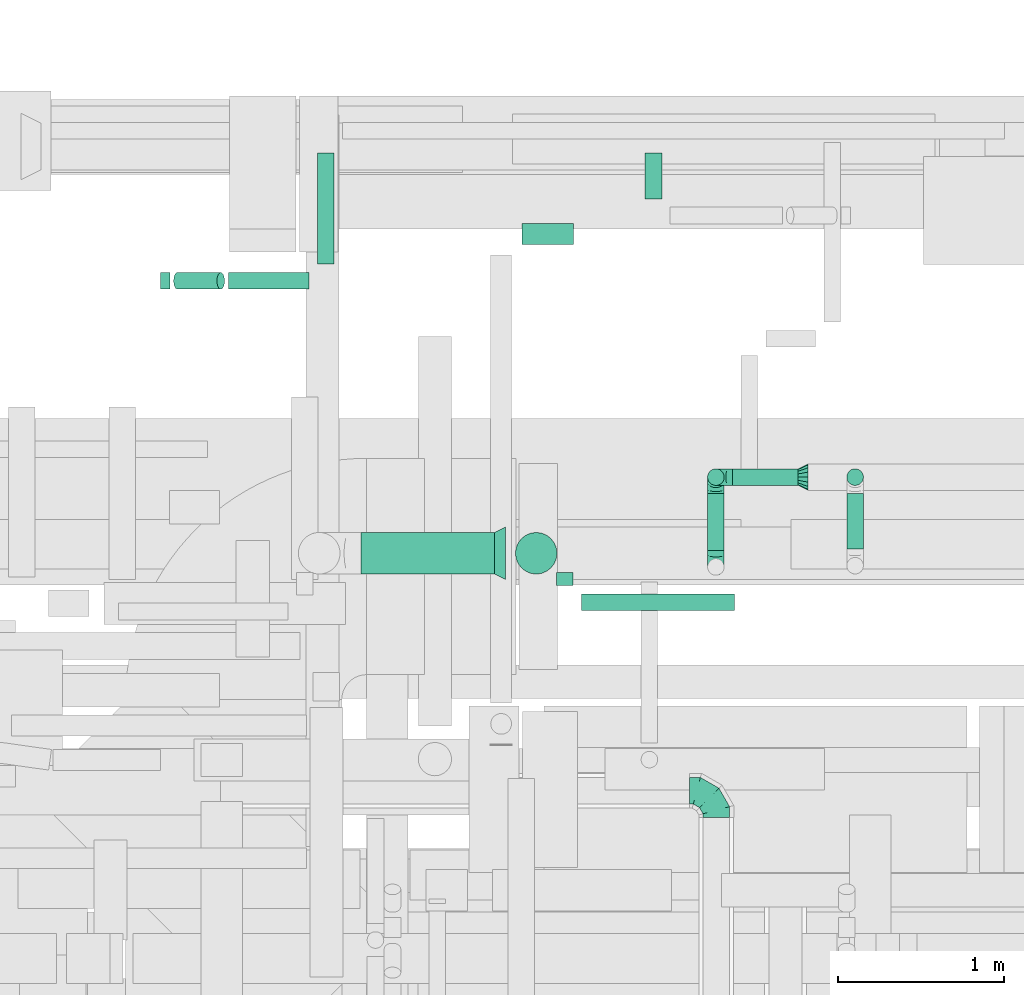
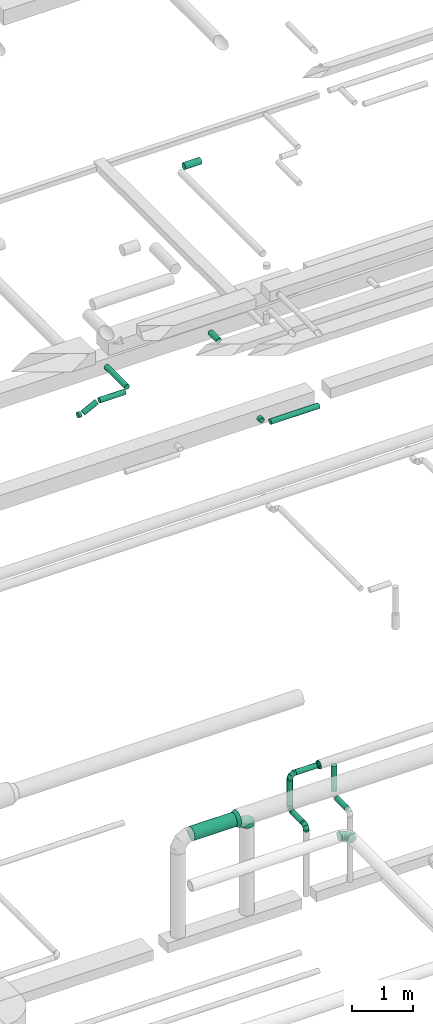
# One storey, part 276 of 337: 14 flow segments, 7 flow fittings.
"""IFC2X3 building model written with IfcOpenShell, lengths in millimetres."""

from ifc_helpers import new_model, entity, si_unit, converted_unit, derived_unit, direction, frame, origin, origin_2d_with_axis, place, context, subcontext, project, spatial, circle, extrude, faceted_brep, source, transform, mapped, material, type_object, type_shapes, element, save


model = new_model("IFC2X3")

# Units and contexts
model_context = context("Model", 3, precision=0.01, world=origin(), true_north=direction((6.12303176911189e-17, 1.0)))
body_context = subcontext(model_context, "Body", "Model", "MODEL_VIEW")
ifc_project = project(units=[si_unit("LENGTHUNIT", "METRE", prefix="MILLI"), si_unit("AREAUNIT", "SQUARE_METRE"), si_unit("VOLUMEUNIT", "CUBIC_METRE"), converted_unit("PLANEANGLEUNIT", "DEGREE", entity("IfcRatioMeasure", 0.0174532925199433), si_unit("PLANEANGLEUNIT", "RADIAN"), dimensions=[0, 0, 0, 0, 0, 0, 0]), si_unit("MASSUNIT", "GRAM", prefix="KILO"), derived_unit("MASSDENSITYUNIT", [(si_unit("MASSUNIT", "GRAM", prefix="KILO"), 1), (si_unit("LENGTHUNIT", "METRE"), -3)]), derived_unit("MOMENTOFINERTIAUNIT", [(si_unit("LENGTHUNIT", "METRE"), 4)]), si_unit("TIMEUNIT", "SECOND"), si_unit("FREQUENCYUNIT", "HERTZ"), si_unit("THERMODYNAMICTEMPERATUREUNIT", "DEGREE_CELSIUS"), derived_unit("THERMALTRANSMITTANCEUNIT", [(si_unit("MASSUNIT", "GRAM", prefix="KILO"), 1), (si_unit("THERMODYNAMICTEMPERATUREUNIT", "KELVIN"), -1), (si_unit("TIMEUNIT", "SECOND"), -3)]), derived_unit("VOLUMETRICFLOWRATEUNIT", [(si_unit("LENGTHUNIT", "METRE"), 3), (si_unit("TIMEUNIT", "SECOND"), -1)]), derived_unit("MASSFLOWRATEUNIT", [(si_unit("MASSUNIT", "GRAM", prefix="KILO"), 1), (si_unit("TIMEUNIT", "SECOND"), -1)]), derived_unit("ROTATIONALFREQUENCYUNIT", [(si_unit("TIMEUNIT", "SECOND"), -1)]), si_unit("ELECTRICCURRENTUNIT", "AMPERE"), si_unit("ELECTRICVOLTAGEUNIT", "VOLT"), si_unit("POWERUNIT", "WATT"), si_unit("FORCEUNIT", "NEWTON", prefix="KILO"), si_unit("ILLUMINANCEUNIT", "LUX"), si_unit("LUMINOUSFLUXUNIT", "LUMEN"), si_unit("LUMINOUSINTENSITYUNIT", "CANDELA"), derived_unit("USERDEFINED", [(si_unit("MASSUNIT", "GRAM", prefix="KILO"), -1), (si_unit("LENGTHUNIT", "METRE"), -2), (si_unit("TIMEUNIT", "SECOND"), 3), (si_unit("LUMINOUSFLUXUNIT", "LUMEN"), 1)]), derived_unit("LINEARVELOCITYUNIT", [(si_unit("LENGTHUNIT", "METRE"), 1), (si_unit("TIMEUNIT", "SECOND"), -1)]), si_unit("PRESSUREUNIT", "PASCAL"), derived_unit("USERDEFINED", [(si_unit("LENGTHUNIT", "METRE"), -2), (si_unit("MASSUNIT", "GRAM", prefix="KILO"), 1), (si_unit("TIMEUNIT", "SECOND"), -2)]), derived_unit("LINEARFORCEUNIT", [(si_unit("MASSUNIT", "GRAM", prefix="KILO"), 1), (si_unit("LENGTHUNIT", "METRE"), 1), (si_unit("TIMEUNIT", "SECOND"), -2), (si_unit("LENGTHUNIT", "METRE"), -1)]), derived_unit("PLANARFORCEUNIT", [(si_unit("MASSUNIT", "GRAM", prefix="KILO"), 1), (si_unit("LENGTHUNIT", "METRE"), 1), (si_unit("TIMEUNIT", "SECOND"), -2), (si_unit("LENGTHUNIT", "METRE"), -2)])], contexts=[model_context])

# Site, building, storey
site_placement = place(None, origin())
site = spatial("IfcSite", under=ifc_project, at=site_placement, CompositionType="ELEMENT")
building_placement = place(site_placement, origin())
building = spatial("IfcBuilding", under=site, at=building_placement, CompositionType="ELEMENT")
storey_placement = place(building_placement, origin())
storey = spatial("IfcBuildingStorey", under=building, at=storey_placement, CompositionType="ELEMENT", Elevation=0.0)

# Flow segments
duct_segment_type = type_object("IfcDuctSegmentType", PredefinedType="NOTDEFINED")
flow_segment_1_placement = place(storey_placement, frame((41270.47, 19229.19, 15235.9)))
element("IfcFlowSegment", 1, at=flow_segment_1_placement, inside=storey, type_object=duct_segment_type, context=body_context, shape_type="SweptSolid", body=[
    extrude(circle(Radius=62.5, at=origin_2d_with_axis()), frame((0.0, 64.1, 64.1), z_axis=(1.0, 0.0, 0.0), x_axis=(0.0, -1.0, 0.0)), (0.0, 0.0, 1.0), 311.408405646729),
])
flow_segment_2_placement = place(storey_placement, frame((39505.12, 18960.04, 11348.4)))
element("IfcFlowSegment", 2, at=flow_segment_2_placement, inside=storey, type_object=duct_segment_type, context=body_context, shape_type="SweptSolid", body=[
    extrude(circle(Radius=50.0, at=origin_2d_with_axis()), frame((0.0, 51.6, 51.6), z_axis=(1.0, 0.0, 0.0), x_axis=(0.0, 1.0, 0.0)), (0.0, 0.0, 1.0), 485.992124091863),
])
flow_segment_3_placement = place(storey_placement, frame((39175.27, 18960.04, 11210.4)))
element("IfcFlowSegment", 3, at=flow_segment_3_placement, inside=storey, type_object=duct_segment_type, context=body_context, shape_type="SweptSolid", body=[
    extrude(circle(Radius=50.0, at=origin_2d_with_axis()), frame((24.29, 51.6, 46.15), z_axis=(0.891006524188362, 0.0, 0.453990499739558), x_axis=(0.0, 1.0, 0.0)), (0.0, 0.0, 1.0), 291.984248184073),
])
flow_segment_4_placement = place(storey_placement, frame((39098.17, 18960.04, 11194.05)))
element("IfcFlowSegment", 4, at=flow_segment_4_placement, inside=storey, type_object=duct_segment_type, context=body_context, shape_type="SweptSolid", body=[
    extrude(circle(Radius=50.0, at=origin_2d_with_axis()), frame((0.0, 51.6, 51.6), z_axis=(1.0, 0.0, 0.0), x_axis=(0.0, 1.0, 0.0)), (0.0, 0.0, 1.0), 55.9921240919866),
])
flow_segment_5_placement = place(storey_placement, frame((41477.14, 17179.24, 11348.4)))
element("IfcFlowSegment", 5, at=flow_segment_5_placement, inside=storey, type_object=duct_segment_type, context=body_context, shape_type="SweptSolid", body=[
    extrude(circle(Radius=50.0, at=origin_2d_with_axis()), frame((51.6, 0.0, 51.6), z_axis=(0.0, 1.0, 0.0), x_axis=(1.0, 0.0, 0.0)), (0.0, 0.0, 1.0), 78.8733549960814),
])
flow_segment_6_placement = place(storey_placement, frame((41628.74, 17027.64, 11348.4)))
element("IfcFlowSegment", 6, at=flow_segment_6_placement, inside=storey, type_object=duct_segment_type, context=body_context, shape_type="SweptSolid", body=[
    extrude(circle(Radius=50.0, at=origin_2d_with_axis()), frame((0.0, 51.6, 51.6), z_axis=(1.0, 0.0, 0.0), x_axis=(0.0, -1.0, 0.0)), (0.0, 0.0, 1.0), 920.000000000007),
])
flow_segment_7_placement = place(storey_placement, frame((40039.52, 19111.64, 11348.4)))
element("IfcFlowSegment", 7, at=flow_segment_7_placement, inside=storey, type_object=duct_segment_type, context=body_context, shape_type="SweptSolid", body=[
    extrude(circle(Radius=50.0, at=origin_2d_with_axis()), frame((51.6, 0.0, 51.6), z_axis=(0.0, 1.0, 0.0), x_axis=(-1.0, 0.0, 0.0)), (0.0, 0.0, 1.0), 669.42061003986),
])
flow_segment_8_placement = place(storey_placement, frame((42009.92, 19504.79, 11348.4)))
element("IfcFlowSegment", 8, at=flow_segment_8_placement, inside=storey, type_object=duct_segment_type, context=body_context, shape_type="SweptSolid", body=[
    extrude(circle(Radius=50.0, at=origin_2d_with_axis()), frame((51.6, 0.0, 51.6), z_axis=(0.0, 1.0, 0.0), x_axis=(-1.0, 0.0, 0.0)), (0.0, 0.0, 1.0), 276.269796034393),
])
flow_segment_9_placement = place(storey_placement, frame((42536.64, 17780.38, 3548.4)))
element("IfcFlowSegment", 9, at=flow_segment_9_placement, inside=storey, type_object=duct_segment_type, context=body_context, shape_type="SweptSolid", body=[
    extrude(circle(Radius=50.0, at=origin_2d_with_axis()), frame((0.0, 51.6, 51.6), z_axis=(1.0, 0.0, 0.0), x_axis=(0.0, 1.0, 0.0)), (0.0, 0.0, 1.0), 395.000000000031),
])
flow_segment_10_placement = place(storey_placement, frame((40301.92, 17247.68, 3309.22)))
element("IfcFlowSegment", 10, at=flow_segment_10_placement, inside=storey, type_object=duct_segment_type, context=body_context, shape_type="SweptSolid", body=[
    extrude(circle(Radius=125.0, at=origin_2d_with_axis()), frame((0.0, 126.6, 126.6), z_axis=(1.0, 0.0, 0.0), x_axis=(0.0, 1.0, 0.0)), (0.0, 0.0, 1.0), 804.999999999982),
])
flow_segment_11_placement = place(storey_placement, frame((42385.05, 17780.38, 3000.0)))
element("IfcFlowSegment", 11, at=flow_segment_11_placement, inside=storey, type_object=duct_segment_type, context=body_context, shape_type="SweptSolid", body=[
    extrude(circle(Radius=50.0, at=origin_2d_with_axis()), frame((51.6, 51.6, 0.0), z_axis=(0.0, 0.0, 1.0), x_axis=(0.0, 1.0, 0.0)), (0.0, 0.0, 1.0), 500.000000000015),
])
flow_segment_12_placement = place(storey_placement, frame((43221.94, 17780.38, 2985.0)))
element("IfcFlowSegment", 12, at=flow_segment_12_placement, inside=storey, type_object=duct_segment_type, context=body_context, shape_type="SweptSolid", body=[
    extrude(circle(Radius=50.0, at=origin_2d_with_axis()), frame((51.6, 51.6, 0.0), z_axis=(0.0, 0.0, 1.0), x_axis=(0.0, 1.0, 0.0)), (0.0, 0.0, 1.0), 514.999999999998),
])
flow_segment_13_placement = place(storey_placement, frame((43221.94, 17399.47, 2833.4)))
element("IfcFlowSegment", 13, at=flow_segment_13_placement, inside=storey, type_object=duct_segment_type, context=body_context, shape_type="SweptSolid", body=[
    extrude(circle(Radius=50.0, at=origin_2d_with_axis()), frame((51.6, 0.0, 51.6), z_axis=(0.0, 1.0, 0.0), x_axis=(-1.0, 0.0, 0.0)), (0.0, 0.0, 1.0), 332.500000000011),
])
flow_segment_14_placement = place(storey_placement, frame((42385.05, 17391.97, 2848.4)))
element("IfcFlowSegment", 14, at=flow_segment_14_placement, inside=storey, type_object=duct_segment_type, context=body_context, shape_type="SweptSolid", body=[
    extrude(circle(Radius=50.0, at=origin_2d_with_axis()), frame((51.6, 0.0, 51.6), z_axis=(0.0, 1.0, 0.0), x_axis=(-1.0, 0.0, 0.0)), (0.0, 0.0, 1.0), 339.999999999999),
])

# Flow fittings
ifc_material = material()
duct_fitting_type_1 = type_object("IfcDuctFittingType", PredefinedType="NOTDEFINED", material=ifc_material)
shared_shape_1 = source(origin(), body_context, "Body", "Brep", [
    faceted_brep([(-160.0, 0.0, -80.0), (-160.0, -20.71, -77.27), (-160.0, -40.0, -69.28), (-160.0, -56.57, -56.57), (-160.0, -69.28, -40.0), (-160.0, -77.27, -20.71), (-160.0, -80.0, 0.0), (-160.0, -77.27, 20.71), (-160.0, -69.28, 40.0), (-160.0, -56.57, 56.57), (-160.0, -40.0, 69.28), (-160.0, -20.71, 77.27), (-160.0, 0.0, 80.0), (-160.0, 20.71, 77.27), (-160.0, 40.0, 69.28), (-160.0, 56.57, 56.57), (-160.0, 69.28, 40.0), (-160.0, 77.27, 20.71), (-160.0, 80.0, 0.0), (-160.0, 77.27, -20.71), (-160.0, 69.28, -40.0), (-160.0, 56.57, -56.57), (-160.0, 40.0, -69.28), (-160.0, 20.71, -77.27), (-122.68, 20.71, 77.27), (-127.85, 40.0, 69.28), (-117.13, 0.0, 80.0), (-132.29, 56.57, 56.57), (-137.83, 77.27, 20.71), (-138.56, 80.0, 0.0), (-135.69, 69.28, 40.0), (-135.69, 69.28, -40.0), (-132.29, 56.57, -56.57), (-137.83, 77.27, -20.71), (-122.68, 20.71, -77.27), (-117.13, 0.0, -80.0), (-127.85, 40.0, -69.28), (-111.58, -20.71, -77.27), (-106.41, -40.0, -69.28), (-101.97, -56.57, -56.57), (-98.56, -69.28, -40.0), (-96.42, -77.27, -20.71), (-95.69, -80.0, 0.0), (-96.42, -77.27, 20.71), (-98.56, -69.28, 40.0), (-101.97, -56.57, 56.57), (-106.41, -40.0, 69.28), (-111.58, -20.71, 77.27), (-58.03, 58.03, 77.27), (-72.15, 72.15, 69.28), (-42.87, 42.87, 80.0), (-84.28, 84.28, 56.57), (-93.59, 93.59, 40.0), (-99.44, 99.44, 20.71), (-101.44, 101.44, 0.0), (-99.44, 99.44, -20.71), (-93.59, 93.59, -40.0), (-84.28, 84.28, -56.57), (-58.03, 58.03, -77.27), (-42.87, 42.87, -80.0), (-72.15, 72.15, -69.28), (-27.71, 27.71, -77.27), (-13.59, 13.59, -69.28), (-1.46, 1.46, -56.57), (7.85, -7.85, -40.0), (13.7, -13.7, -20.71), (15.69, -15.69, 0.0), (13.7, -13.7, 20.71), (7.85, -7.85, 40.0), (-1.46, 1.46, 56.57), (-13.59, 13.59, 69.28), (-27.71, 27.71, 77.27), (-20.71, 122.68, 77.27), (-40.0, 127.85, 69.28), (0.0, 117.13, 80.0), (-56.57, 132.29, 56.57), (-69.28, 135.69, 40.0), (-77.27, 137.83, 20.71), (-80.0, 138.56, 0.0), (-77.27, 137.83, -20.71), (-69.28, 135.69, -40.0), (-56.57, 132.29, -56.57), (-20.71, 122.68, -77.27), (0.0, 117.13, -80.0), (-40.0, 127.85, -69.28), (20.71, 111.58, -77.27), (40.0, 106.41, -69.28), (56.57, 101.97, -56.57), (69.28, 98.56, -40.0), (77.27, 96.42, -20.71), (80.0, 95.69, 0.0), (77.27, 96.42, 20.71), (69.28, 98.56, 40.0), (56.57, 101.97, 56.57), (40.0, 106.41, 69.28), (20.71, 111.58, 77.27), (-20.71, 160.0, -77.27), (-40.0, 160.0, -69.28), (-56.57, 160.0, -56.57), (-69.28, 160.0, -40.0), (-77.27, 160.0, -20.71), (-80.0, 160.0, 0.0), (-77.27, 160.0, 20.71), (-69.28, 160.0, 40.0), (-56.57, 160.0, 56.57), (-40.0, 160.0, 69.28), (-20.71, 160.0, 77.27), (0.0, 160.0, 80.0), (20.71, 160.0, 77.27), (40.0, 160.0, 69.28), (56.57, 160.0, 56.57), (69.28, 160.0, 40.0), (77.27, 160.0, 20.71), (80.0, 160.0, 0.0), (77.27, 160.0, -20.71), (69.28, 160.0, -40.0), (56.57, 160.0, -56.57), (40.0, 160.0, -69.28), (20.71, 160.0, -77.27), (0.0, 160.0, -80.0)], [[[0, 1, 2, 3, 4, 5, 6, 7, 8, 9, 10, 11, 12, 13, 14, 15, 16, 17, 18, 19, 20, 21, 22, 23]], [[24, 25, 14, 13]], [[26, 24, 13, 12]], [[14, 25, 27, 15]], [[28, 29, 18, 17]], [[30, 28, 17, 16]], [[15, 27, 30, 16]], [[20, 31, 32, 21]], [[33, 31, 20, 19]], [[18, 29, 33, 19]], [[34, 35, 0, 23]], [[36, 34, 23, 22]], [[32, 36, 22, 21]], [[1, 0, 35, 37]], [[2, 1, 37, 38]], [[3, 2, 38, 39]], [[5, 4, 40, 41]], [[6, 5, 41, 42]], [[39, 40, 4, 3]], [[6, 42, 43, 7]], [[7, 43, 44, 8]], [[8, 44, 45, 9]], [[9, 45, 46, 10]], [[10, 46, 47, 11]], [[26, 12, 11, 47]], [[48, 49, 25, 24]], [[50, 48, 24, 26]], [[27, 25, 49, 51]], [[52, 53, 28, 30]], [[51, 52, 30, 27]], [[29, 28, 53, 54]], [[55, 56, 31, 33]], [[54, 55, 33, 29]], [[32, 31, 56, 57]], [[58, 59, 35, 34]], [[60, 58, 34, 36]], [[57, 60, 36, 32]], [[37, 35, 59, 61]], [[38, 37, 61, 62]], [[39, 38, 62, 63]], [[41, 40, 64, 65]], [[42, 41, 65, 66]], [[63, 64, 40, 39]], [[43, 42, 66, 67]], [[44, 43, 67, 68]], [[68, 69, 45, 44]], [[46, 45, 69, 70]], [[47, 46, 70, 71]], [[26, 47, 71, 50]], [[72, 73, 49, 48]], [[74, 72, 48, 50]], [[51, 49, 73, 75]], [[76, 77, 53, 52]], [[75, 76, 52, 51]], [[54, 53, 77, 78]], [[79, 80, 56, 55]], [[78, 79, 55, 54]], [[57, 56, 80, 81]], [[82, 83, 59, 58]], [[84, 82, 58, 60]], [[81, 84, 60, 57]], [[61, 59, 83, 85]], [[62, 61, 85, 86]], [[63, 62, 86, 87]], [[65, 64, 88, 89]], [[66, 65, 89, 90]], [[87, 88, 64, 63]], [[67, 66, 90, 91]], [[68, 67, 91, 92]], [[92, 93, 69, 68]], [[70, 69, 93, 94]], [[71, 70, 94, 95]], [[50, 71, 95, 74]], [[96, 97, 98, 99, 100, 101, 102, 103, 104, 105, 106, 107, 108, 109, 110, 111, 112, 113, 114, 115, 116, 117, 118, 119]], [[72, 74, 107, 106]], [[73, 72, 106, 105]], [[75, 73, 105, 104]], [[77, 76, 103, 102]], [[78, 77, 102, 101]], [[75, 104, 103, 76]], [[78, 101, 100, 79]], [[79, 100, 99, 80]], [[80, 99, 98, 81]], [[84, 97, 96, 82]], [[82, 96, 119, 83]], [[84, 81, 98, 97]], [[118, 117, 86, 85]], [[119, 118, 85, 83]], [[116, 87, 86, 117]], [[88, 115, 114, 89]], [[89, 114, 113, 90]], [[115, 88, 87, 116]], [[112, 111, 92, 91]], [[113, 112, 91, 90]], [[111, 110, 93, 92]], [[95, 94, 109, 108]], [[74, 95, 108, 107]], [[110, 109, 94, 93]]]),
])
type_shapes(duct_fitting_type_1, [shared_shape_1])
flow_fitting_1_placement = place(storey_placement, frame((42439.16, 15946.4, 3550.0), z_axis=(0.0, 0.0, 1.0), x_axis=(0.0, 1.0, 0.0)))
element("IfcFlowFitting", 15, at=flow_fitting_1_placement, inside=storey, type_object=duct_fitting_type_1, material=ifc_material, context=body_context, shape_type="MappedRepresentation", body=[
    mapped(shared_shape_1, transform((0.0, 0.0, 0.0), scale=1.0)),
])
duct_fitting_type_2 = type_object("IfcDuctFittingType", PredefinedType="NOTDEFINED", material=ifc_material)
shared_shape_2 = source(origin(), body_context, "Body", "Brep", [
    faceted_brep([(-100.0, 0.0, -50.0), (-100.0, -12.94, -48.3), (-100.0, -25.0, -43.3), (-100.0, -35.36, -35.36), (-100.0, -43.3, -25.0), (-100.0, -48.3, -12.94), (-100.0, -50.0, 0.0), (-100.0, -48.3, 12.94), (-100.0, -43.3, 25.0), (-100.0, -35.36, 35.36), (-100.0, -25.0, 43.3), (-100.0, -12.94, 48.3), (-100.0, 0.0, 50.0), (-100.0, 12.94, 48.3), (-100.0, 25.0, 43.3), (-100.0, 35.36, 35.36), (-100.0, 43.3, 25.0), (-100.0, 48.3, 12.94), (-100.0, 50.0, 0.0), (-100.0, 48.3, -12.94), (-100.0, 43.3, -25.0), (-100.0, 35.36, -35.36), (-100.0, 25.0, -43.3), (-100.0, 12.94, -48.3), (-76.67, 12.94, 48.3), (-79.9, 25.0, 43.3), (-73.21, 0.0, 50.0), (-82.68, 35.36, 35.36), (-86.15, 48.3, 12.94), (-86.6, 50.0, 0.0), (-84.81, 43.3, 25.0), (-84.81, 43.3, -25.0), (-82.68, 35.36, -35.36), (-86.15, 48.3, -12.94), (-76.67, 12.94, -48.3), (-73.21, 0.0, -50.0), (-79.9, 25.0, -43.3), (-69.74, -12.94, -48.3), (-66.51, -25.0, -43.3), (-63.73, -35.36, -35.36), (-61.6, -43.3, -25.0), (-60.26, -48.3, -12.94), (-59.81, -50.0, 0.0), (-60.26, -48.3, 12.94), (-61.6, -43.3, 25.0), (-63.73, -35.36, 35.36), (-66.51, -25.0, 43.3), (-69.74, -12.94, 48.3), (-36.27, 36.27, 48.3), (-45.1, 45.1, 43.3), (-26.79, 26.79, 50.0), (-52.68, 52.68, 35.36), (-58.49, 58.49, 25.0), (-62.15, 62.15, 12.94), (-63.4, 63.4, 0.0), (-62.15, 62.15, -12.94), (-58.49, 58.49, -25.0), (-52.68, 52.68, -35.36), (-36.27, 36.27, -48.3), (-26.79, 26.79, -50.0), (-45.1, 45.1, -43.3), (-17.32, 17.32, -48.3), (-8.49, 8.49, -43.3), (-0.91, 0.91, -35.36), (4.9, -4.9, -25.0), (8.56, -8.56, -12.94), (9.81, -9.81, 0.0), (8.56, -8.56, 12.94), (4.9, -4.9, 25.0), (-0.91, 0.91, 35.36), (-8.49, 8.49, 43.3), (-17.32, 17.32, 48.3), (-12.94, 76.67, 48.3), (-25.0, 79.9, 43.3), (0.0, 73.21, 50.0), (-35.36, 82.68, 35.36), (-43.3, 84.81, 25.0), (-48.3, 86.15, 12.94), (-50.0, 86.6, 0.0), (-48.3, 86.15, -12.94), (-43.3, 84.81, -25.0), (-35.36, 82.68, -35.36), (-12.94, 76.67, -48.3), (0.0, 73.21, -50.0), (-25.0, 79.9, -43.3), (12.94, 69.74, -48.3), (25.0, 66.51, -43.3), (35.36, 63.73, -35.36), (43.3, 61.6, -25.0), (48.3, 60.26, -12.94), (50.0, 59.81, 0.0), (48.3, 60.26, 12.94), (43.3, 61.6, 25.0), (35.36, 63.73, 35.36), (25.0, 66.51, 43.3), (12.94, 69.74, 48.3), (-12.94, 100.0, -48.3), (-25.0, 100.0, -43.3), (-35.36, 100.0, -35.36), (-43.3, 100.0, -25.0), (-48.3, 100.0, -12.94), (-50.0, 100.0, 0.0), (-48.3, 100.0, 12.94), (-43.3, 100.0, 25.0), (-35.36, 100.0, 35.36), (-25.0, 100.0, 43.3), (-12.94, 100.0, 48.3), (0.0, 100.0, 50.0), (12.94, 100.0, 48.3), (25.0, 100.0, 43.3), (35.36, 100.0, 35.36), (43.3, 100.0, 25.0), (48.3, 100.0, 12.94), (50.0, 100.0, 0.0), (48.3, 100.0, -12.94), (43.3, 100.0, -25.0), (35.36, 100.0, -35.36), (25.0, 100.0, -43.3), (12.94, 100.0, -48.3), (0.0, 100.0, -50.0)], [[[0, 1, 2, 3, 4, 5, 6, 7, 8, 9, 10, 11, 12, 13, 14, 15, 16, 17, 18, 19, 20, 21, 22, 23]], [[24, 25, 14, 13]], [[26, 24, 13, 12]], [[14, 25, 27, 15]], [[28, 29, 18, 17]], [[30, 28, 17, 16]], [[15, 27, 30, 16]], [[20, 31, 32, 21]], [[33, 31, 20, 19]], [[18, 29, 33, 19]], [[34, 35, 0, 23]], [[36, 34, 23, 22]], [[32, 36, 22, 21]], [[2, 1, 37, 38]], [[3, 2, 38, 39]], [[0, 35, 37, 1]], [[5, 4, 40, 41]], [[6, 5, 41, 42]], [[3, 39, 40, 4]], [[6, 42, 43, 7]], [[7, 43, 44, 8]], [[8, 44, 45, 9]], [[10, 46, 47, 11]], [[11, 47, 26, 12]], [[10, 9, 45, 46]], [[48, 49, 25, 24]], [[50, 48, 24, 26]], [[27, 25, 49, 51]], [[52, 53, 28, 30]], [[51, 52, 30, 27]], [[29, 28, 53, 54]], [[55, 56, 31, 33]], [[54, 55, 33, 29]], [[57, 32, 31, 56]], [[58, 59, 35, 34]], [[60, 58, 34, 36]], [[57, 60, 36, 32]], [[37, 35, 59, 61]], [[38, 37, 61, 62]], [[39, 38, 62, 63]], [[41, 40, 64, 65]], [[42, 41, 65, 66]], [[63, 64, 40, 39]], [[43, 42, 66, 67]], [[44, 43, 67, 68]], [[68, 69, 45, 44]], [[46, 45, 69, 70]], [[47, 46, 70, 71]], [[26, 47, 71, 50]], [[72, 73, 49, 48]], [[74, 72, 48, 50]], [[51, 49, 73, 75]], [[76, 77, 53, 52]], [[75, 76, 52, 51]], [[54, 53, 77, 78]], [[79, 80, 56, 55]], [[78, 79, 55, 54]], [[81, 57, 56, 80]], [[82, 83, 59, 58]], [[84, 82, 58, 60]], [[81, 84, 60, 57]], [[61, 59, 83, 85]], [[62, 61, 85, 86]], [[63, 62, 86, 87]], [[65, 64, 88, 89]], [[66, 65, 89, 90]], [[87, 88, 64, 63]], [[67, 66, 90, 91]], [[68, 67, 91, 92]], [[92, 93, 69, 68]], [[70, 69, 93, 94]], [[71, 70, 94, 95]], [[50, 71, 95, 74]], [[96, 97, 98, 99, 100, 101, 102, 103, 104, 105, 106, 107, 108, 109, 110, 111, 112, 113, 114, 115, 116, 117, 118, 119]], [[72, 74, 107, 106]], [[73, 72, 106, 105]], [[75, 73, 105, 104]], [[77, 76, 103, 102]], [[78, 77, 102, 101]], [[75, 104, 103, 76]], [[78, 101, 100, 79]], [[79, 100, 99, 80]], [[80, 99, 98, 81]], [[96, 119, 83, 82]], [[97, 96, 82, 84]], [[84, 81, 98, 97]], [[83, 119, 118, 85]], [[85, 118, 117, 86]], [[86, 117, 116, 87]], [[88, 115, 114, 89]], [[89, 114, 113, 90]], [[87, 116, 115, 88]], [[91, 90, 113, 112]], [[92, 91, 112, 111]], [[93, 92, 111, 110]], [[95, 94, 109, 108]], [[74, 95, 108, 107]], [[110, 109, 94, 93]]]),
])
type_shapes(duct_fitting_type_2, [shared_shape_2])
for number, where, z_axis, x_axis in (
    (16, (42436.64, 17831.97, 3600.0), (0.0, -1.0, 0.0), (-1.0, 0.0, 0.0)),
    (17, (42436.64, 17831.97, 2900.0), (-1.0, 0.0, 0.0), (0.0, 0.0, -1.0)),
    (18, (42436.64, 17291.97, 2900.0), (1.0, 0.0, 0.0), (0.0, -1.0, 0.0)),
):
    element("IfcFlowFitting", number, at=place(storey_placement, frame(where, z_axis=z_axis, x_axis=x_axis)), inside=storey, type_object=duct_fitting_type_2, material=ifc_material, context=body_context, shape_type="MappedRepresentation", body=[
        mapped(shared_shape_2, transform((0.0, 0.0, 0.0), scale=1.0)),
    ])
duct_fitting_type_3 = type_object("IfcDuctFittingType", PredefinedType="NOTDEFINED", material=ifc_material)
shared_shape_3 = source(origin(), body_context, "Body", "Brep", [
    faceted_brep([(60.0, 0.0, -80.0), (60.0, 14.27, -77.16), (60.0, 30.61, -73.91), (60.0, 43.59, -65.24), (60.0, 56.57, -56.57), (60.0, 65.24, -43.59), (60.0, 73.91, -30.61), (60.0, 77.16, -14.27), (60.0, 80.0, 0.0), (60.0, 77.16, 14.27), (60.0, 73.91, 30.61), (60.0, 65.24, 43.59), (60.0, 56.57, 56.57), (60.0, 43.59, 65.24), (60.0, 30.61, 73.91), (60.0, 14.27, 77.16), (60.0, 0.0, 80.0), (60.0, -14.27, 77.16), (60.0, -30.61, 73.91), (60.0, -43.59, 65.24), (60.0, -56.57, 56.57), (60.0, -65.24, 43.59), (60.0, -73.91, 30.61), (60.0, -77.16, 14.27), (60.0, -80.0, 0.0), (60.0, -77.16, -14.27), (60.0, -73.91, -30.61), (60.0, -65.24, -43.59), (60.0, -56.57, -56.57), (60.0, -43.59, -65.24), (60.0, -30.61, -73.91), (60.0, -14.27, -77.16), (0.0, -19.13, -46.19), (0.0, -27.24, -40.77), (0.0, -35.36, -35.36), (0.0, -40.77, -27.24), (0.0, -46.19, -19.13), (0.0, -48.1, -9.57), (0.0, -50.0, 0.0), (0.0, -48.1, 9.57), (0.0, -46.19, 19.13), (0.0, -40.77, 27.24), (0.0, -35.36, 35.36), (0.0, -27.24, 40.77), (0.0, -19.13, 46.19), (0.0, -9.57, 48.1), (0.0, 0.0, 50.0), (0.0, 9.57, 48.1), (0.0, 19.13, 46.19), (0.0, 27.24, 40.77), (0.0, 35.36, 35.36), (0.0, 40.77, 27.24), (0.0, 46.19, 19.13), (0.0, 48.1, 9.57), (0.0, 50.0, 0.0), (0.0, 48.1, -9.57), (0.0, 46.19, -19.13), (0.0, 40.77, -27.24), (0.0, 35.36, -35.36), (0.0, 27.24, -40.77), (0.0, 19.13, -46.19), (0.0, 9.57, -48.1), (0.0, 0.0, -50.0), (0.0, -9.57, -48.1)], [[[0, 1, 2, 3, 4, 5, 6, 7, 8, 9, 10, 11, 12, 13, 14, 15, 16, 17, 18, 19, 20, 21, 22, 23, 24, 25, 26, 27, 28, 29, 30, 31]], [[32, 33, 34, 35, 36, 37, 38, 39, 40, 41, 42, 43, 44, 45, 46, 47, 48, 49, 50, 51, 52, 53, 54, 55, 56, 57, 58, 59, 60, 61, 62, 63]], [[52, 51, 50, 12, 11, 10]], [[48, 14, 13, 12, 50, 49]], [[10, 9, 8, 54, 53, 52]], [[15, 14, 48, 47, 46, 16]], [[44, 43, 42, 20, 19, 18]], [[40, 22, 21, 20, 42, 41]], [[18, 17, 16, 46, 45, 44]], [[23, 22, 40, 39, 38, 24]], [[36, 35, 34, 28, 27, 26]], [[32, 30, 29, 28, 34, 33]], [[26, 25, 24, 38, 37, 36]], [[31, 30, 32, 63, 62, 0]], [[60, 59, 58, 4, 3, 2]], [[56, 6, 5, 4, 58, 57]], [[2, 1, 0, 62, 61, 60]], [[7, 6, 56, 55, 54, 8]]]),
])
type_shapes(duct_fitting_type_3, [shared_shape_3])
flow_fitting_2_placement = place(storey_placement, frame((42931.64, 17831.97, 3600.0)))
element("IfcFlowFitting", 19, at=flow_fitting_2_placement, inside=storey, type_object=duct_fitting_type_3, material=ifc_material, context=body_context, shape_type="MappedRepresentation", body=[
    mapped(shared_shape_3, transform((0.0, 0.0, 0.0), scale=1.0)),
])
duct_fitting_type_4 = type_object("IfcDuctFittingType", PredefinedType="NOTDEFINED", material=ifc_material)
shared_shape_4 = source(origin(), body_context, "Body", "Brep", [
    faceted_brep([(20.0, 32.35, -120.74), (20.0, 62.5, -108.25), (20.0, 88.39, -88.39), (20.0, 108.25, -62.5), (20.0, 120.74, -32.35), (20.0, 125.0, 0.0), (20.0, 120.74, 32.35), (20.0, 108.25, 62.5), (20.0, 88.39, 88.39), (20.0, 62.5, 108.25), (20.0, 32.35, 120.74), (20.0, 0.0, 125.0), (20.0, -32.35, 120.74), (20.0, -62.5, 108.25), (20.0, -88.39, 88.39), (20.0, -108.25, 62.5), (20.0, -120.74, 32.35), (20.0, -125.0, 0.0), (20.0, -120.74, -32.35), (20.0, -108.25, -62.5), (20.0, -88.39, -88.39), (20.0, -62.5, -108.25), (20.0, -32.35, -120.74), (20.0, 0.0, -125.0), (0.0, 0.0, 125.0), (0.0, 32.35, 120.74), (-67.78, 32.35, 120.74), (-67.78, 0.0, 125.0), (0.0, 62.5, 108.25), (-67.78, 62.5, 108.25), (0.0, 88.39, 88.39), (-67.78, 88.39, 88.39), (0.0, 108.25, 62.5), (0.0, 120.74, 32.35), (-67.78, 120.74, 32.35), (-67.78, 108.25, 62.5), (0.0, 125.0, 0.0), (-67.78, 125.0, 0.0), (0.0, 120.74, -32.35), (-67.78, 120.74, -32.35), (0.0, 108.25, -62.5), (-67.78, 108.25, -62.5), (0.0, 88.39, -88.39), (-67.78, 88.39, -88.39), (0.0, 62.5, -108.25), (0.0, 32.35, -120.74), (-67.78, 32.35, -120.74), (-67.78, 62.5, -108.25), (0.0, 0.0, -125.0), (-67.78, 0.0, -125.0), (0.0, -32.35, -120.74), (-67.78, -32.35, -120.74), (0.0, -62.5, -108.25), (-67.78, -62.5, -108.25), (0.0, -88.39, -88.39), (-67.78, -88.39, -88.39), (0.0, -108.25, -62.5), (0.0, -120.74, -32.35), (-67.78, -120.74, -32.35), (-67.78, -108.25, -62.5), (0.0, -125.0, 0.0), (-67.78, -125.0, 0.0), (0.0, -120.74, 32.35), (-67.78, -120.74, 32.35), (0.0, -108.25, 62.5), (-67.78, -108.25, 62.5), (0.0, -88.39, 88.39), (-67.78, -88.39, 88.39), (0.0, -62.5, 108.25), (0.0, -32.35, 120.74), (-67.78, -32.35, 120.74), (-67.78, -62.5, 108.25)], [[[0, 1, 2, 3, 4, 5, 6, 7, 8, 9, 10, 11, 12, 13, 14, 15, 16, 17, 18, 19, 20, 21, 22, 23]], [[24, 11, 10, 25, 26, 27]], [[25, 10, 9, 28, 29, 26]], [[28, 9, 8, 30, 31, 29]], [[32, 7, 6, 33, 34, 35]], [[33, 6, 5, 36, 37, 34]], [[30, 8, 7, 32, 35, 31]], [[36, 5, 4, 38, 39, 37]], [[38, 4, 3, 40, 41, 39]], [[40, 3, 2, 42, 43, 41]], [[44, 1, 0, 45, 46, 47]], [[45, 0, 23, 48, 49, 46]], [[42, 2, 1, 44, 47, 43]], [[48, 23, 22, 50, 51, 49]], [[50, 22, 21, 52, 53, 51]], [[52, 21, 20, 54, 55, 53]], [[56, 19, 18, 57, 58, 59]], [[57, 18, 17, 60, 61, 58]], [[54, 20, 19, 56, 59, 55]], [[60, 17, 16, 62, 63, 61]], [[62, 16, 15, 64, 65, 63]], [[64, 15, 14, 66, 67, 65]], [[68, 13, 12, 69, 70, 71]], [[69, 12, 11, 24, 27, 70]], [[66, 14, 13, 68, 71, 67]], [[49, 51, 53, 55, 59, 58, 61, 63, 65, 67, 71, 70, 27, 26, 29, 31, 35, 34, 37, 39, 41, 43, 47, 46]]]),
])
type_shapes(duct_fitting_type_4, [shared_shape_4])
flow_fitting_3_placement = place(storey_placement, frame((41356.32, 17374.28, 3278.32), z_axis=(1.0, 0.0, 0.0), x_axis=(0.0, 0.0, -1.0)))
element("IfcFlowFitting", 20, at=flow_fitting_3_placement, inside=storey, type_object=duct_fitting_type_4, material=ifc_material, context=body_context, shape_type="MappedRepresentation", body=[
    mapped(shared_shape_4, transform((0.0, 0.0, 0.0), scale=1.0)),
])
duct_fitting_type_5 = type_object("IfcDuctFittingType", PredefinedType="NOTDEFINED", material=ifc_material)
shared_shape_5 = source(origin(), body_context, "Body", "Brep", [
    faceted_brep([(65.0, -78.75, -136.4), (65.0, -40.76, -152.13), (65.0, 0.0, -157.5), (65.0, 40.76, -152.13), (65.0, 78.75, -136.4), (65.0, 111.37, -111.37), (65.0, 136.4, -78.75), (65.0, 152.13, -40.76), (65.0, 157.5, 0.0), (65.0, 152.13, 40.76), (65.0, 136.4, 78.75), (65.0, 111.37, 111.37), (65.0, 78.75, 136.4), (65.0, 40.76, 152.13), (65.0, 0.0, 157.5), (65.0, -40.76, 152.13), (65.0, -78.75, 136.4), (65.0, -111.37, 111.37), (65.0, -136.4, 78.75), (65.0, -152.13, 40.76), (65.0, -157.5, 0.0), (65.0, -152.13, -40.76), (65.0, -136.4, -78.75), (65.0, -111.37, -111.37), (0.0, 38.63, -118.88), (0.0, 0.0, -125.0), (0.0, -38.63, -118.88), (0.0, -73.47, -101.13), (0.0, -101.13, -73.47), (0.0, -118.88, -38.63), (0.0, -125.0, 0.0), (0.0, -118.88, 38.63), (0.0, -101.13, 73.47), (0.0, -73.47, 101.13), (0.0, -38.63, 118.88), (0.0, 0.0, 125.0), (0.0, 38.63, 118.88), (0.0, 73.47, 101.13), (0.0, 101.13, 73.47), (0.0, 118.88, 38.63), (0.0, 125.0, 0.0), (0.0, 118.88, -38.63), (0.0, 101.13, -73.47), (0.0, 73.47, -101.13)], [[[0, 1, 2, 3, 4, 5, 6, 7, 8, 9, 10, 11, 12, 13, 14, 15, 16, 17, 18, 19, 20, 21, 22, 23]], [[24, 25, 26, 27, 28, 29, 30, 31, 32, 33, 34, 35, 36, 37, 38, 39, 40, 41, 42, 43]], [[39, 38, 10]], [[40, 39, 9]], [[40, 9, 8]], [[9, 39, 10]], [[38, 11, 10]], [[36, 35, 13]], [[37, 36, 12]], [[12, 11, 37]], [[13, 12, 36]], [[35, 14, 13]], [[37, 11, 38]], [[34, 33, 16]], [[35, 34, 15]], [[35, 15, 14]], [[15, 34, 16]], [[33, 17, 16]], [[31, 30, 19]], [[32, 31, 18]], [[18, 17, 32]], [[19, 18, 31]], [[30, 20, 19]], [[32, 17, 33]], [[29, 28, 22]], [[30, 29, 21]], [[30, 21, 20]], [[21, 29, 22]], [[28, 23, 22]], [[26, 25, 1]], [[27, 26, 0]], [[0, 23, 27]], [[1, 0, 26]], [[25, 2, 1]], [[27, 23, 28]], [[24, 43, 4]], [[25, 24, 3]], [[25, 3, 2]], [[3, 24, 4]], [[43, 5, 4]], [[41, 40, 7]], [[42, 41, 6]], [[6, 5, 42]], [[7, 6, 41]], [[40, 8, 7]], [[42, 5, 43]]]),
])
type_shapes(duct_fitting_type_5, [shared_shape_5])
flow_fitting_4_placement = place(storey_placement, frame((41106.92, 17374.28, 3434.54)))
element("IfcFlowFitting", 21, at=flow_fitting_4_placement, inside=storey, type_object=duct_fitting_type_5, material=ifc_material, context=body_context, shape_type="MappedRepresentation", body=[
    mapped(shared_shape_5, transform((0.0, 0.0, 0.0), scale=1.0)),
])

save(model, "model.ifc")
